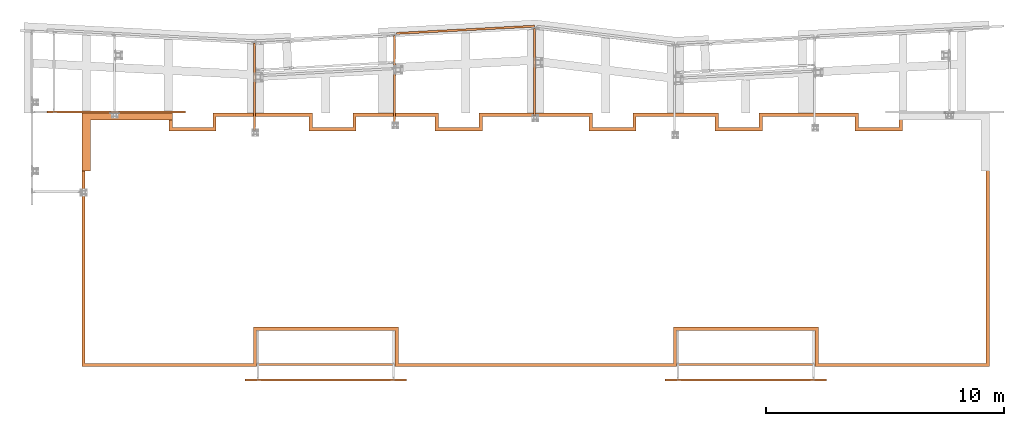
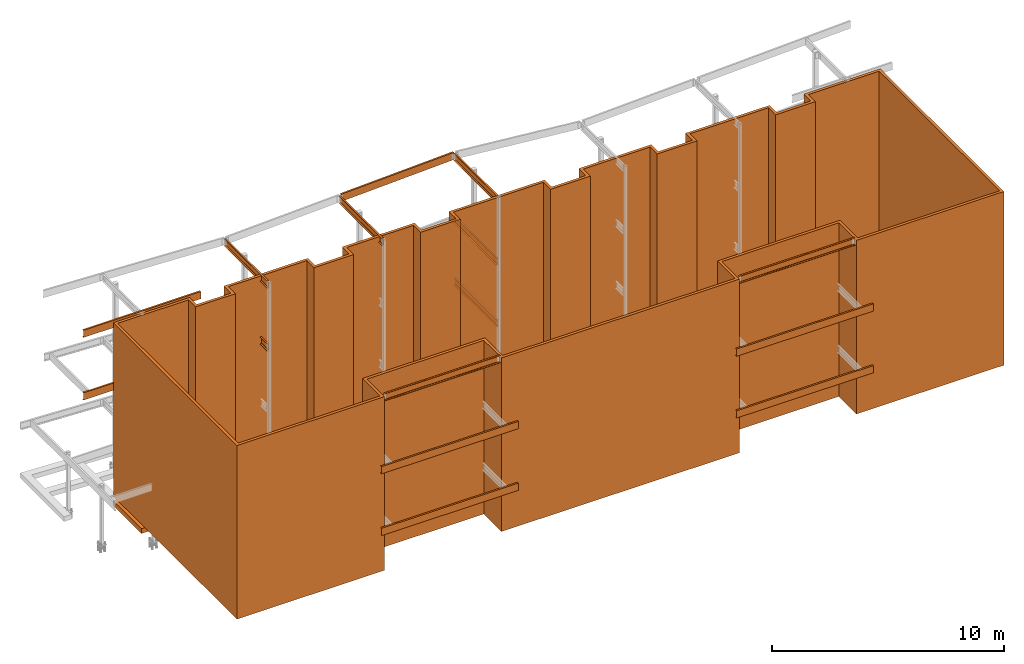
# One storey, part 3 of 89: 17 proxies.
"""IFC4 building model written with IfcOpenShell, lengths in feet."""

from ifc_helpers import new_model, entity, si_unit, converted_unit, derived_unit, direction, frame, frame_2d, origin, place, context, subcontext, project, spatial, polyline, rectangle, outline, extrude, source, transform, mapped, material, type_object, type_shapes, element, save


model = new_model("IFC4")

# Units and contexts
model_context = context("Model", 3, precision=0.0001, world=origin(), true_north=direction((6.12303176911189e-17, 1.0)))
body_context = subcontext(model_context, "Body", "Model", "MODEL_VIEW")
ifc_project = project(units=[converted_unit("LENGTHUNIT", "FOOT", entity("IfcRatioMeasure", 0.3048), si_unit("LENGTHUNIT", "METRE"), dimensions=[1, 0, 0, 0, 0, 0, 0]), converted_unit("AREAUNIT", "SQUARE FOOT", entity("IfcRatioMeasure", 0.09290304), si_unit("AREAUNIT", "SQUARE_METRE"), dimensions=[2, 0, 0, 0, 0, 0, 0]), converted_unit("VOLUMEUNIT", "CUBIC FOOT", entity("IfcRatioMeasure", 0.028316846592), si_unit("VOLUMEUNIT", "CUBIC_METRE"), dimensions=[3, 0, 0, 0, 0, 0, 0]), si_unit("PLANEANGLEUNIT", "RADIAN"), si_unit("MASSUNIT", "GRAM", prefix="KILO"), derived_unit("MASSDENSITYUNIT", [(si_unit("MASSUNIT", "GRAM", prefix="KILO"), 1), (si_unit("LENGTHUNIT", "METRE"), -3)]), derived_unit("MOMENTOFINERTIAUNIT", [(si_unit("LENGTHUNIT", "METRE"), 4)]), si_unit("TIMEUNIT", "SECOND"), si_unit("FREQUENCYUNIT", "HERTZ"), si_unit("THERMODYNAMICTEMPERATUREUNIT", "DEGREE_CELSIUS"), derived_unit("THERMALTRANSMITTANCEUNIT", [(si_unit("MASSUNIT", "GRAM", prefix="KILO"), 1), (si_unit("THERMODYNAMICTEMPERATUREUNIT", "KELVIN"), -1), (si_unit("TIMEUNIT", "SECOND"), -3)]), derived_unit("VOLUMETRICFLOWRATEUNIT", [(si_unit("LENGTHUNIT", "METRE"), 3), (si_unit("TIMEUNIT", "SECOND"), -1)]), si_unit("ELECTRICCURRENTUNIT", "AMPERE"), si_unit("ELECTRICVOLTAGEUNIT", "VOLT"), si_unit("POWERUNIT", "WATT"), si_unit("FORCEUNIT", "NEWTON"), si_unit("ILLUMINANCEUNIT", "LUX"), si_unit("LUMINOUSFLUXUNIT", "LUMEN"), si_unit("LUMINOUSINTENSITYUNIT", "CANDELA"), derived_unit("USERDEFINED", [(si_unit("MASSUNIT", "GRAM", prefix="KILO"), -1), (si_unit("LENGTHUNIT", "METRE"), -2), (si_unit("TIMEUNIT", "SECOND"), 3), (si_unit("LUMINOUSFLUXUNIT", "LUMEN"), 1)]), derived_unit("LINEARVELOCITYUNIT", [(si_unit("LENGTHUNIT", "METRE"), 1), (si_unit("TIMEUNIT", "SECOND"), -1)]), si_unit("PRESSUREUNIT", "PASCAL"), derived_unit("USERDEFINED", [(si_unit("LENGTHUNIT", "METRE"), -2), (si_unit("MASSUNIT", "GRAM", prefix="KILO"), 1), (si_unit("TIMEUNIT", "SECOND"), -2)]), derived_unit("LINEARFORCEUNIT", [(si_unit("MASSUNIT", "GRAM", prefix="KILO"), 1), (si_unit("LENGTHUNIT", "METRE"), 1), (si_unit("TIMEUNIT", "SECOND"), -2), (si_unit("LENGTHUNIT", "METRE"), -1)]), derived_unit("PLANARFORCEUNIT", [(si_unit("MASSUNIT", "GRAM", prefix="KILO"), 1), (si_unit("LENGTHUNIT", "METRE"), 1), (si_unit("TIMEUNIT", "SECOND"), -2), (si_unit("LENGTHUNIT", "METRE"), -2)])], contexts=[model_context])

# Site, building, storey
site_placement = place(None, origin())
site = spatial("IfcSite", under=ifc_project, at=site_placement, CompositionType="ELEMENT")
building_placement = place(site_placement, frame((-472.238160486, -49.138065117, 0.0)))
building = spatial("IfcBuilding", under=site, at=building_placement, CompositionType="ELEMENT")
storey_placement = place(building_placement, origin())
storey = spatial("IfcBuildingStorey", under=building, at=storey_placement, Name="Level 1", CompositionType="ELEMENT", Elevation=0.0)

# Proxies
ifc_material_1 = material(Name="Color", Category="Materials")
building_element_proxy_type_1 = type_object("IfcBuildingElementProxyType", Name="M_22", PredefinedType="NOTDEFINED", material=ifc_material_1)
shared_shape_1 = source(origin(), body_context, "Body", "SweptSolid", [
    extrude(outline(polyline([(-5.02777777777771, -3.38888888888889), (-5.02777777777771, -4.55555555555554), (2.97222222222229, -4.55555555555554), (2.97222222222229, 7.94444444444446), (2.05555555555566, 7.94444444444446), (2.05555555555566, -3.38888888888889), (-5.02777777777771, -3.38888888888889)])), frame((4.55555555555554, 5.02777777777771, 0.0), z_axis=(0.0, 0.0, -1.0), x_axis=(0.0, 1.0, 0.0)), (0.0, 0.0, -1.0), 0.833333333333333),
])
type_shapes(building_element_proxy_type_1, [shared_shape_1])
proxy_1_placement = place(building_placement, frame((206.486634871424, 1000.0, -0.833333333333333)))
element("IfcBuildingElementProxy", 1, at=proxy_1_placement, inside=storey, type_object=building_element_proxy_type_1, material=ifc_material_1, Name="M_22:M_22", ObjectType="M_22:M_22", PredefinedType="NOTDEFINED", context=body_context, shape_type="MappedRepresentation", body=[
    mapped(shared_shape_1, transform((0.0, 0.0, 0.0), scale=1.0)),
])
building_element_proxy_type_2 = type_object("IfcBuildingElementProxyType", Name="e61", PredefinedType="NOTDEFINED", material=ifc_material_1)
shared_shape_2 = source(origin(), body_context, "Body", "SweptSolid", [
    extrude(outline(polyline([(-45.462962962963, -2.52314814814838), (-45.462962962963, 2.01851851851825), (-45.9212962962964, 2.01851851851825), (-45.9212962962964, -2.98148148148175), (-25.900462962963, -2.98148148148175), (-25.900462962963, 2.01851851851825), (12.0787037037036, 2.01851851851825), (12.0787037037036, -2.98148148148175), (32.099537037037, -2.98148148148175), (32.099537037037, 2.01851851851825), (55.287037037037, 2.01851851851825), (55.287037037037, 2.47685185185162), (31.6412037037036, 2.47685185185162), (31.6412037037036, -2.52314814814838), (12.537037037037, -2.52314814814838), (12.537037037037, 2.47685185185162), (-26.3587962962964, 2.47685185185162), (-26.3587962962964, -2.52314814814838), (-45.462962962963, -2.52314814814838)])), frame((69.5879629629626, 2.47685185185162, 0.0), z_axis=(0.0, 0.0, -1.0), x_axis=(1.0, 0.0, 0.0)), (0.0, 0.0, -1.0), 30.0),
    extrude(rectangle(XDim=23.6666666666667, YDim=0.458333333333371, at=frame_2d((0.0, 5.6843418860808e-14), x_axis=(1.0, 0.0))), frame((12.291666666666, 0.229166666667084, 0.0), z_axis=(0.0, 0.0, 1.0), x_axis=(-1.0, 0.0, 0.0)), (0.0, 0.0, 1.0), 30.0),
    extrude(outline(polyline([(-7.8125, 4.72916666666674), (-7.8125, 6.27083333333348), (-8.27083333333334, 6.27083333333348), (-8.27083333333334, 4.27083333333348), (-1.77083333333334, 4.27083333333348), (-1.77083333333334, 6.27083333333348), (9.8125, 6.27083333333348), (9.8125, -28.2708333333333), (10.2708333333333, -28.2708333333333), (10.2708333333333, 6.72916666666674), (-2.22916666666669, 6.72916666666674), (-2.22916666666669, 4.72916666666674), (-7.8125, 4.72916666666674)])), frame((10.2708333333333, 28.2708333333369, 0.0), z_axis=(0.0, 0.0, -1.0), x_axis=(-1.0, 0.0, 0.0)), (0.0, 0.0, -1.0), 30.0),
    extrude(outline(polyline([(-26.5625, -1.02916666666658), (-11.3541666666666, -1.02916666666658), (-11.3541666666666, 0.970833333333417), (-5.77083333333337, 0.970833333333417), (-5.77083333333337, -1.02916666666658), (6.06249999999997, -1.02916666666658), (6.06249999999997, 0.970833333333417), (11.6458333333333, 0.970833333333417), (11.6458333333333, -1.02916666666658), (25.3958333333333, -1.02916666666658), (25.3958333333333, -0.570833333333212), (12.1041666666666, -0.570833333333212), (12.1041666666666, 1.42916666666679), (5.60416666666663, 1.42916666666679), (5.60416666666663, -0.570833333333212), (-5.31250000000003, -0.570833333333212), (-5.31250000000003, 1.42916666666679), (-11.8125, 1.42916666666679), (-11.8125, -0.570833333333212), (-26.5625, -0.570833333333212), (-26.5625, -1.02916666666658)])), frame((43.4791666666666, 33.9708333333338, 0.0), z_axis=(0.0, 0.0, 1.0), x_axis=(-1.0, 0.0, 0.0)), (0.0, 0.0, 1.0), 30.0),
    extrude(outline(polyline([(-11.5000000000001, -0.770833333333258), (-11.5000000000001, 0.770833333333371), (-11.9583333333334, 0.770833333333371), (-11.9583333333334, -1.22916666666663), (-5.45833333333337, -1.22916666666663), (-5.45833333333337, 0.770833333333371), (5.45833333333326, 0.770833333333371), (5.45833333333326, -1.22916666666663), (11.9583333333333, -1.22916666666663), (11.9583333333333, 1.22916666666674), (11.4999999999999, 1.22916666666674), (11.4999999999999, -0.770833333333258), (5.91666666666663, -0.770833333333258), (5.91666666666663, 1.22916666666674), (-5.91666666666674, 1.22916666666674), (-5.91666666666674, -0.770833333333258), (-11.5000000000001, -0.770833333333258)])), frame((82.0, 33.770833333337, 0.0), z_axis=(0.0, 0.0, -1.0), x_axis=(-1.0, 0.0, 0.0)), (0.0, 0.0, -1.0), 30.0),
    extrude(outline(polyline([(-6.25, 7.02083333333326), (-5.79166666666669, 7.02083333333326), (-5.79166666666669, 9.02083333333326), (5.79166666666669, 9.02083333333326), (5.79166666666669, -25.5208333333335), (6.25, -25.5208333333335), (6.25, 9.47916666666652), (-6.25, 9.47916666666652), (-6.25, 7.02083333333326)])), frame((119.083333333333, 25.5208333333371, 0.0)), (0.0, 0.0, 1.0), 30.0),
    extrude(rectangle(XDim=5.58333333333331, YDim=0.458333333333371, at=frame_2d((2.8421709430404e-14, 5.6843418860808e-14), x_axis=(1.0, 0.0))), frame((110.041666666666, 32.7708333333371, 0.0), z_axis=(0.0, 0.0, 1.0), x_axis=(-1.0, 0.0, 0.0)), (0.0, 0.0, 1.0), 30.0),
    extrude(rectangle(XDim=0.458333333333314, YDim=2.0, at=frame_2d((-2.8421709430404e-14, 0.0), x_axis=(1.0, 0.0))), frame((107.020833333333, 33.5416666666704, 0.0), z_axis=(0.0, 0.0, 1.0), x_axis=(-1.0, 0.0, 0.0)), (0.0, 0.0, 1.0), 30.0),
    extrude(rectangle(XDim=13.75, YDim=0.458333333333371, at=frame_2d((0.0, 5.6843418860808e-14), x_axis=(1.0, 0.0))), frame((100.375, 34.7708333333371, 0.0), z_axis=(0.0, 0.0, 1.0), x_axis=(-1.0, 0.0, 0.0)), (0.0, 0.0, 1.0), 30.0),
])
type_shapes(building_element_proxy_type_2, [shared_shape_2])
proxy_2_placement = place(building_placement, frame((206.5, 973.0, 0.75)))
element("IfcBuildingElementProxy", 2, at=proxy_2_placement, inside=storey, type_object=building_element_proxy_type_2, material=ifc_material_1, Name="e61:e61", ObjectType="e61:e61", PredefinedType="NOTDEFINED", context=body_context, shape_type="MappedRepresentation", body=[
    mapped(shared_shape_2, transform((0.0, 0.0, 0.0), scale=1.0)),
])
ifc_material_2 = material(Name="Color 7720", Category="Materials")
building_element_proxy_type_3 = type_object("IfcBuildingElementProxyType", Name="BEAM 9680:BEAM 9680", PredefinedType="NOTDEFINED", material=ifc_material_2)
shared_shape_3 = source(origin(), body_context, "Body", "SweptSolid", [
    extrude(outline(polyline([(-0.625, -0.18082846105208), (-0.591665944192121, -0.18082846105208), (-0.557364297421449, 0.024988557054672), (-0.551184769668311, 0.0424107340231663), (-0.539385739901635, 0.0566410435819367), (-0.523409352768051, 0.0659401762152094), (-0.505208333333333, 0.0691715389479203), (0.505208333333333, 0.0691715389479203), (0.523409352768051, 0.0659401762152094), (0.539385739901635, 0.0566410435819367), (0.551184769668311, 0.0424107340231663), (0.557364297421449, 0.0249885570546721), (0.591665944192121, -0.18082846105208), (0.625, -0.18082846105208), (0.625, 0.102504872281254), (-0.625, 0.102504872281254), (-0.625, -0.18082846105208)])), frame((0.0, -0.625, 0.102504872281254), z_axis=(1.0, 0.0, 0.0), x_axis=(0.0, -1.0, 0.0)), (0.0, 0.0, 1.0), 18.9583333333333),
])
type_shapes(building_element_proxy_type_3, [shared_shape_3])
for number, where, z_axis, x_axis, name in (
    (3, (288.6875, 973.458333333333, 31.0833333333333), (0.0, -1.0, 0.0), (1.0, 0.0, 0.0), "c255"),
    (4, (230.6875, 973.458333333333, 31.0833333333333), (0.0, -1.0, 0.0), (1.0, 0.0, 0.0), "c255"),
):
    element("IfcBuildingElementProxy", number, at=place(building_placement, frame(where, z_axis=z_axis, x_axis=x_axis)), inside=storey, type_object=building_element_proxy_type_3, material=ifc_material_2, Name=name, ObjectType="BEAM", PredefinedType="NOTDEFINED", context=body_context, shape_type="MappedRepresentation", body=[
        mapped(shared_shape_3, transform((0.0, 0.0, 0.0), scale=1.0)),
    ])
building_element_proxy_type_4 = type_object("IfcBuildingElementProxyType", Name="BEAM 9649:BEAM 9649", PredefinedType="NOTDEFINED", material=ifc_material_2)
shared_shape_4 = source(origin(), body_context, "Body", "SweptSolid", [
    extrude(outline(polyline([(-0.625, -0.102504872281253), (0.625, -0.102504872281253), (0.625, 0.180828461052087), (0.59166594419212, 0.180828461052087), (0.557364297421448, -0.0249885570546883), (0.551184769668311, -0.0424107340231546), (0.539385739901633, -0.0566410435819523), (0.523409352768051, -0.0659401762152121), (0.505208333333333, -0.0691715389479131), (-0.505208333333333, -0.0691715389479131), (-0.523409352768051, -0.0659401762152121), (-0.539385739901633, -0.0566410435819523), (-0.551184769668311, -0.0424107340231546), (-0.557364297421448, -0.0249885570546883), (-0.59166594419212, 0.180828461052087), (-0.625, 0.180828461052087), (-0.625, -0.102504872281253)])), frame((0.0, 0.625, 0.180828461052087), z_axis=(1.0, 0.0, 0.0), x_axis=(0.0, -1.0, 0.0)), (0.0, 0.0, 1.0), 12.100194730959),
])
type_shapes(building_element_proxy_type_4, [shared_shape_4])
for number, where, z_axis, x_axis, name in (
    (5, (268.883333333334, 1007.609375, 29.8333333333333), (1.0, 0.0, 0.0), (0.0, 1.0, 0.0), "c766"),
    (6, (230.216666666667, 1005.58333333333, 29.8333333333333), (1.0, 0.0, 0.0), (0.0, 1.0, 0.0), "c766"),
    (7, (249.55, 1006.59895833333, 29.8333333333333), (1.0, 0.0, 0.0), (0.0, 1.0, 0.0), "c766"),
):
    element("IfcBuildingElementProxy", number, at=place(building_placement, frame(where, z_axis=z_axis, x_axis=x_axis)), inside=storey, type_object=building_element_proxy_type_4, material=ifc_material_2, Name=name, ObjectType="BEAM", PredefinedType="NOTDEFINED", context=body_context, shape_type="MappedRepresentation", body=[
        mapped(shared_shape_4, transform((0.0, 0.0, 0.0), scale=1.0)),
    ])
building_element_proxy_type_5 = type_object("IfcBuildingElementProxyType", Name="BEAM 9606:BEAM 9606", PredefinedType="NOTDEFINED", material=ifc_material_2)
shared_shape_5 = source(origin(), body_context, "Body", "SweptSolid", [
    extrude(outline(polyline([(-0.625, -0.10250487228124), (0.625, -0.10250487228124), (0.625, 0.180828461052064), (0.59166594419212, 0.180828461052064), (0.557364297421448, -0.0249885570546364), (0.551184769668311, -0.0424107340231028), (0.539385739901635, -0.0566410435819763), (0.523409352768051, -0.0659401762152361), (0.505208333333333, -0.0691715389479361), (-0.505208333333333, -0.0691715389479361), (-0.523409352768051, -0.0659401762152361), (-0.539385739901635, -0.0566410435819763), (-0.551184769668311, -0.0424107340231028), (-0.557364297421448, -0.0249885570546364), (-0.59166594419212, 0.180828461052064), (-0.625, 0.180828461052064), (-0.625, -0.10250487228124)])), frame((0.0, -0.625, -0.10250487228124), z_axis=(1.0, 0.0, 0.0), x_axis=(0.0, -1.0, 0.0)), (0.0, 0.0, 1.0), 19.1666666666667),
])
type_shapes(building_element_proxy_type_5, [shared_shape_5])
for number, where, z_axis, x_axis, name in (
    (8, (201.666666666667, 1008.04166666667, 31.0833333333333), (0.0, -1.0, 0.0), (1.0, 0.0, 0.0), "c721"),
    (9, (201.666666666667, 1008.04166666667, 20.2708333333333), (0.0, -1.0, 0.0), (1.0, 0.0, 0.0), "c724"),
):
    element("IfcBuildingElementProxy", number, at=place(building_placement, frame(where, z_axis=z_axis, x_axis=x_axis)), inside=storey, type_object=building_element_proxy_type_5, material=ifc_material_2, Name=name, ObjectType="BEAM", PredefinedType="NOTDEFINED", context=body_context, shape_type="MappedRepresentation", body=[
        mapped(shared_shape_5, transform((0.0, 0.0, 0.0), scale=1.0)),
    ])
building_element_proxy_type_6 = type_object("IfcBuildingElementProxyType", Name="BEAM 9622:BEAM 9622", PredefinedType="NOTDEFINED", material=ifc_material_2)
shared_shape_6 = source(origin(), body_context, "Body", "SweptSolid", [
    extrude(outline(polyline([(-0.625, -0.102504872281253), (0.625, -0.102504872281253), (0.625, 0.180828461052087), (0.591665944192121, 0.180828461052087), (0.557364297421448, -0.0249885570546884), (0.551184769668311, -0.0424107340231546), (0.539385739901635, -0.0566410435819523), (0.523409352768051, -0.0659401762152121), (0.505208333333333, -0.0691715389479131), (-0.505208333333333, -0.0691715389479131), (-0.523409352768051, -0.0659401762152121), (-0.539385739901635, -0.0566410435819523), (-0.551184769668311, -0.0424107340231546), (-0.557364297421448, -0.0249885570546883), (-0.591665944192121, 0.180828461052087), (-0.625, 0.180828461052087), (-0.625, -0.102504872281253)])), frame((0.0, 0.625, 0.180828461052087), z_axis=(1.0, 0.0, 0.0), x_axis=(0.0, -1.0, 0.0)), (0.0, 0.0, 1.0), 12.0653726812722),
])
type_shapes(building_element_proxy_type_6, [shared_shape_6])
for number, where, z_axis, x_axis, name in (
    (10, (268.883333333334, 1007.609375, 19.0208333333333), (1.0, 0.0, 0.0), (0.0, 1.0, 0.0), "c758"),
    (11, (268.883333333334, 1007.609375, 8.35416666666667), (1.0, 0.0, 0.0), (0.0, 1.0, 0.0), "c743"),
):
    element("IfcBuildingElementProxy", number, at=place(building_placement, frame(where, z_axis=z_axis, x_axis=x_axis)), inside=storey, type_object=building_element_proxy_type_6, material=ifc_material_2, Name=name, ObjectType="BEAM", PredefinedType="NOTDEFINED", context=body_context, shape_type="MappedRepresentation", body=[
        mapped(shared_shape_6, transform((0.0, 0.0, 0.0), scale=1.0)),
    ])
building_element_proxy_type_7 = type_object("IfcBuildingElementProxyType", Name="BEAM 9603:BEAM 9603", PredefinedType="NOTDEFINED", material=ifc_material_2)
shared_shape_7 = source(origin(), body_context, "Body", "SweptSolid", [
    extrude(outline(polyline([(-0.625, -0.102504872281253), (0.625, -0.102504872281253), (0.625, 0.180828461052087), (0.59166594419212, 0.180828461052087), (0.557364297421448, -0.0249885570546883), (0.551184769668311, -0.0424107340231546), (0.539385739901635, -0.0566410435819523), (0.523409352768051, -0.0659401762152121), (0.505208333333333, -0.0691715389479131), (-0.505208333333333, -0.0691715389479131), (-0.523409352768051, -0.0659401762152121), (-0.539385739901635, -0.0566410435819523), (-0.551184769668311, -0.0424107340231546), (-0.557364297421448, -0.0249885570546883), (-0.59166594419212, 0.180828461052087), (-0.625, 0.180828461052087), (-0.625, -0.102504872281253)])), frame((0.0, 0.625, 0.180828461052087), z_axis=(1.0, 0.0, 0.0), x_axis=(0.0, -1.0, 0.0)), (0.0, 0.0, 1.0), 12.0417389484667),
])
type_shapes(building_element_proxy_type_7, [shared_shape_7])
proxy_3_placement = place(building_placement, frame((230.216666666667, 1005.58333333333, 19.0208333333333), z_axis=(1.0, 0.0, 0.0), x_axis=(0.0, 1.0, 0.0)))
element("IfcBuildingElementProxy", 12, at=proxy_3_placement, inside=storey, type_object=building_element_proxy_type_7, material=ifc_material_2, Name="c763", ObjectType="BEAM", PredefinedType="NOTDEFINED", context=body_context, shape_type="MappedRepresentation", body=[
    mapped(shared_shape_7, transform((0.0, 0.0, 0.0), scale=1.0)),
])
building_element_proxy_type_8 = type_object("IfcBuildingElementProxyType", Name="BEAM 9647:BEAM 9647", PredefinedType="NOTDEFINED", material=ifc_material_2)
shared_shape_8 = source(origin(), body_context, "Body", "SweptSolid", [
    extrude(outline(polyline([(-0.625, -0.102504872281272), (0.625, -0.102504872281272), (0.625, 0.180828461052101), (0.59166594419212, 0.180828461052101), (0.557364297421448, -0.0249885570547281), (0.551184769668311, -0.0424107340230898), (0.539385739901633, -0.0566410435819937), (0.523409352768051, -0.0659401762151579), (0.505208333333333, -0.0691715389479609), (-0.505208333333333, -0.0691715389479609), (-0.523409352768051, -0.0659401762151579), (-0.539385739901633, -0.0566410435819937), (-0.551184769668311, -0.0424107340230898), (-0.557364297421448, -0.0249885570547281), (-0.59166594419212, 0.180828461052101), (-0.625, 0.180828461052101), (-0.625, -0.102504872281272)])), frame((0.0, 0.625, 0.180828461052101), z_axis=(1.0, 0.0, 0.0), x_axis=(0.0, -1.0, 0.0)), (0.0, 0.0, 1.0), 19.0576968428471),
])
type_shapes(building_element_proxy_type_8, [shared_shape_8])
proxy_4_placement = place(building_placement, frame((249.96416270039, 1019.15397816749, 29.8333333333333), z_axis=(0.0522520500592836, -0.998633928556707, 0.0), x_axis=(0.998633928556707, 0.0522520500592836, 0.0)))
element("IfcBuildingElementProxy", 13, at=proxy_4_placement, inside=storey, type_object=building_element_proxy_type_8, material=ifc_material_2, Name="24B1", ObjectType="BEAM", PredefinedType="NOTDEFINED", context=body_context, shape_type="MappedRepresentation", body=[
    mapped(shared_shape_8, transform((0.0, 0.0, 0.0), scale=1.0)),
])
building_element_proxy_type_9 = type_object("IfcBuildingElementProxyType", Name="BEAM:BEAM", PredefinedType="NOTDEFINED", material=ifc_material_2)
shared_shape_9 = source(origin(), body_context, "Body", "SweptSolid", [
    extrude(outline(polyline([(-0.625, -0.10250487228124), (0.625, -0.10250487228124), (0.625, 0.180828461052064), (0.591665944192121, 0.180828461052064), (0.557364297421448, -0.0249885570546365), (0.551184769668311, -0.0424107340231028), (0.539385739901635, -0.0566410435819763), (0.523409352768051, -0.0659401762152361), (0.505208333333333, -0.0691715389479361), (-0.505208333333333, -0.0691715389479361), (-0.523409352768051, -0.0659401762152361), (-0.539385739901635, -0.0566410435819763), (-0.551184769668311, -0.0424107340231028), (-0.557364297421448, -0.0249885570546364), (-0.591665944192121, 0.180828461052064), (-0.625, 0.180828461052064), (-0.625, -0.10250487228124)])), frame((0.0, -0.625, -0.10250487228124), z_axis=(1.0, 0.0, 0.0), x_axis=(0.0, -1.0, 0.0)), (0.0, 0.0, 1.0), 22.3333333333333),
])
type_shapes(building_element_proxy_type_9, [shared_shape_9])
for number, where, z_axis, x_axis, name in (
    (14, (287.0, 971.0, 20.4375), (0.0, -1.0, 0.0), (1.0, 0.0, 0.0), "67B1"),
    (15, (229.0, 971.0, 20.4375), (0.0, -1.0, 0.0), (1.0, 0.0, 0.0), "61B1"),
    (16, (287.0, 971.0, 9.77083333333333), (0.0, -1.0, 0.0), (1.0, 0.0, 0.0), "67B1"),
    (17, (229.0, 971.0, 9.77083333333333), (0.0, -1.0, 0.0), (1.0, 0.0, 0.0), "61B1"),
):
    element("IfcBuildingElementProxy", number, at=place(building_placement, frame(where, z_axis=z_axis, x_axis=x_axis)), inside=storey, type_object=building_element_proxy_type_9, material=ifc_material_2, Name=name, ObjectType="BEAM", PredefinedType="NOTDEFINED", context=body_context, shape_type="MappedRepresentation", body=[
        mapped(shared_shape_9, transform((0.0, 0.0, 0.0), scale=1.0)),
    ])

save(model, "model.ifc")
